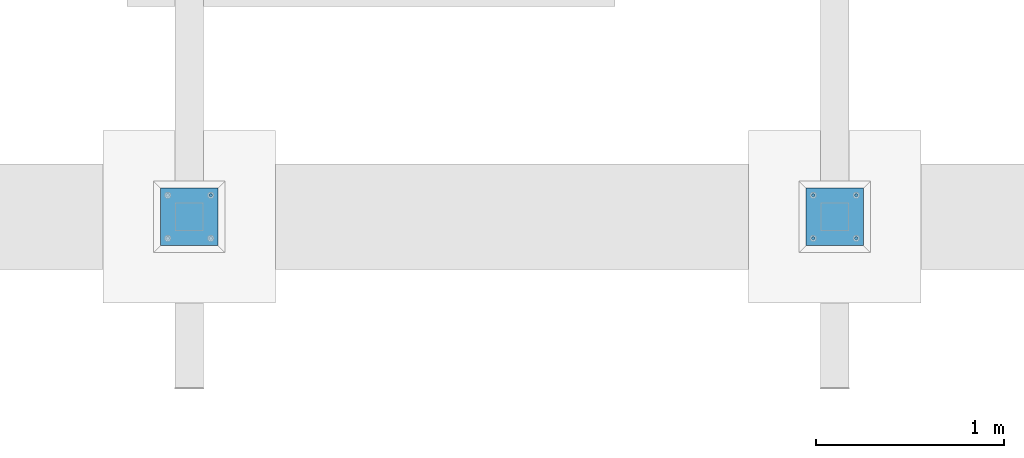
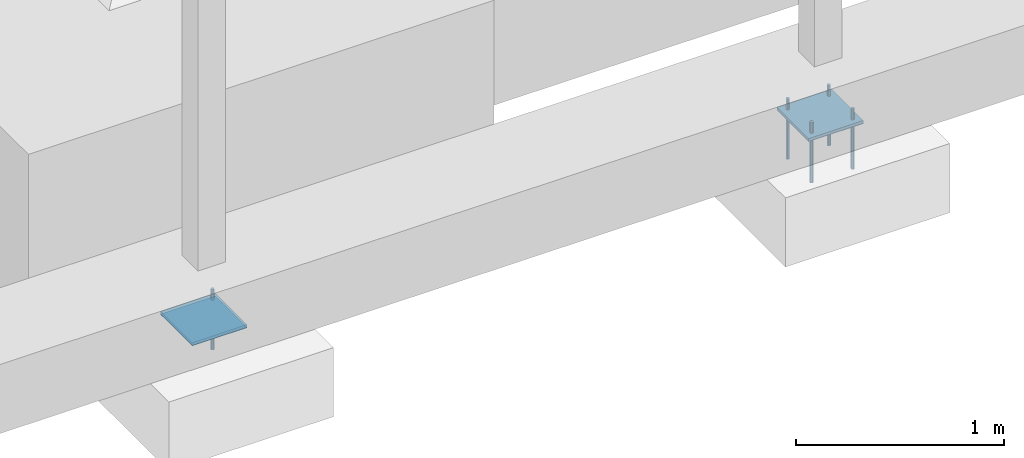
# One storey, part 846 of 1179: 9 beams, 4 elements without a shape of their own.
"""IFC2X3 building model written with IfcOpenShell, lengths in millimetres."""

from ifc_helpers import new_model, si_unit, frame, origin_with_axes, place, context, subcontext, project, spatial, faceted_brep, material, type_object, element, aggregate, save


model = new_model("IFC2X3")

# Units and contexts
model_context = context("Model", 3, precision=1e-05, world=origin_with_axes())
body_context = subcontext(model_context, "Body", "Model", "MODEL_VIEW")
ifc_project = project(units=[si_unit("LENGTHUNIT", "METRE", prefix="MILLI"), si_unit("AREAUNIT", "SQUARE_METRE"), si_unit("VOLUMEUNIT", "CUBIC_METRE"), si_unit("MASSUNIT", "GRAM", prefix="KILO"), si_unit("TIMEUNIT", "SECOND"), si_unit("PLANEANGLEUNIT", "RADIAN"), si_unit("SOLIDANGLEUNIT", "STERADIAN"), si_unit("THERMODYNAMICTEMPERATUREUNIT", "DEGREE_CELSIUS"), si_unit("LUMINOUSINTENSITYUNIT", "LUMEN")], contexts=[model_context])

# Site, building, storey
site_placement = place(None, origin_with_axes())
site = spatial("IfcSite", under=ifc_project, at=site_placement, CompositionType="ELEMENT")
building_placement = place(site_placement, origin_with_axes())
building = spatial("IfcBuilding", under=site, at=building_placement, Name="Undefined", CompositionType="ELEMENT")
storey_placement = place(building_placement, origin_with_axes())
storey = spatial("IfcBuildingStorey", under=building, at=storey_placement, Name="Undefined", CompositionType="ELEMENT", Elevation=0.0)

# Assembly, beam
assembly_1_placement = place(storey_placement, origin_with_axes())
assembly_1 = element("IfcElementAssembly", 1, at=assembly_1_placement, inside=storey, Name="COLUMN", AssemblyPlace="NOTDEFINED", PredefinedType="RIGID_FRAME")
ifc_material_1 = material(Name="STEEL/A572-GR.50")
beam_type_1 = type_object("IfcBeamType", PredefinedType="NOTDEFINED")
beam_1_placement = place(assembly_1_placement, frame((26797.0, 2082.80000305176, -765.175), z_axis=(-1.0, 0.0, 0.0), x_axis=(0.0, 1.0, 0.0)))
beam_1 = element("IfcBeam", 2, at=beam_1_placement, type_object=beam_type_1, material=ifc_material_1, context=body_context, shape_type="Brep", body=[
    faceted_brep([(0.0, 9.52500000000146, -152.4), (0.0, 9.52500000000146, 152.4), (304.799993896484, 9.52499999999998, 152.400000000001), (304.799993896484, 9.52499999999998, -152.400000000001), (0.0, -9.52500000000146, 152.4), (304.799993896484, -9.52499999999998, 152.400000000001), (0.0, -9.52500000000146, -152.4), (304.799993896484, -9.52499999999998, -152.400000000001)], [[[0, 1, 2, 3]], [[1, 4, 5, 2]], [[4, 6, 7, 5]], [[6, 0, 3, 7]], [[5, 7, 3, 2]], [[6, 4, 1, 0]]]),
])
aggregate(assembly_1, [beam_1])

assembly_2_placement = place(storey_placement, origin_with_axes())
assembly_2 = element("IfcElementAssembly", 3, at=assembly_2_placement, inside=storey, Name="COLUMN", AssemblyPlace="NOTDEFINED", PredefinedType="RIGID_FRAME")
beam_2_placement = place(assembly_2_placement, frame((30226.0, 2082.80000305176, -765.175), z_axis=(-1.0, 0.0, 0.0), x_axis=(0.0, 1.0, 0.0)))
beam_2 = element("IfcBeam", 4, at=beam_2_placement, type_object=beam_type_1, material=ifc_material_1, context=body_context, shape_type="Brep", body=[
    faceted_brep([(0.0, 9.52500000000146, -152.4), (0.0, 9.52500000000146, 152.4), (304.799993896484, 9.52499999999998, 152.400000000001), (304.799993896484, 9.52499999999998, -152.400000000001), (0.0, -9.52500000000146, 152.4), (304.799993896484, -9.52499999999998, 152.400000000001), (0.0, -9.52500000000146, -152.4), (304.799993896484, -9.52499999999998, -152.400000000001)], [[[0, 1, 2, 3]], [[1, 4, 5, 2]], [[4, 6, 7, 5]], [[6, 0, 3, 7]], [[5, 7, 3, 2]], [[6, 4, 1, 0]]]),
])
aggregate(assembly_2, [beam_2])

# Assembly, beams
assembly_3_placement = place(storey_placement, origin_with_axes())
assembly_3 = element("IfcElementAssembly", 5, at=assembly_3_placement, inside=storey, Name="TEMPLATE", AssemblyPlace="NOTDEFINED", PredefinedType="RIGID_FRAME")
ifc_material_2 = material(Name="STEEL/F1554-GR.36")
beam_type_2 = type_object("IfcBeamType", PredefinedType="NOTDEFINED")
beam_3_placement = place(assembly_3_placement, frame((30111.7, 2120.9, -812.8), z_axis=(0.0, -1.0, 0.0), x_axis=(0.0, 0.0, -1.0)))
beam_3 = element("IfcBeam", 6, at=beam_3_placement, type_object=beam_type_2, material=ifc_material_2, Name="ANCHOR_BOLT", context=body_context, shape_type="Brep", body=[
    faceted_brep([(0.0, -6.73519209080177, -6.73519209080223), (2.95075507493764e-12, -3.62376795237651e-13, -9.52499961853027), (234.949, 0.0, -9.52500000000009), (234.949, -6.73519209080405, -6.73519209080177), (0.0, 6.73519209080177, -6.73519209080223), (234.949, 6.73519209080405, -6.73519209080177), (0.0, 9.52499999999964, 0.0), (234.949, 9.52500000000146, 0.0), (0.0, 6.73519209080177, 6.73519209080223), (234.949, 6.73519209080405, 6.73519209080177), (-9.87109982941227e-13, -3.62376795237651e-13, 9.52499961853027), (234.949, 0.0, 9.52500000000009), (0.0, -6.73519209080177, 6.73519209080223), (234.949, -6.73519209080405, 6.73519209080177), (0.0, -9.52499999999964, 0.0), (234.949, -9.52500000000146, 0.0), (0.0, 6.36396103067818, 6.36396103067909), (0.0, 0.0, 9.0), (0.0, -6.36396103067818, 6.36396103067909), (0.0, -9.0, 0.0), (0.0, -6.36396103067818, -6.36396103067909), (0.0, 0.0, -9.0), (0.0, 6.36396103067818, -6.36396103067909), (0.0, 9.0, 0.0), (-120.65, -6.36396103067818, 6.36396103067909), (-120.65, 0.0, 9.0), (-120.65, 6.36396103067818, 6.36396103067909), (-120.65, 9.0, 0.0), (-120.65, 6.36396103067818, -6.36396103067909), (-120.65, 0.0, -9.0), (-120.65, -6.36396103067818, -6.36396103067909), (-120.65, -9.0, 0.0)], [[[0, 1, 2, 3]], [[1, 4, 5, 2]], [[4, 6, 7, 5]], [[6, 8, 9, 7]], [[8, 10, 11, 9]], [[10, 12, 13, 11]], [[12, 14, 15, 13]], [[2, 5, 7, 9, 11, 13, 15, 3]], [[14, 0, 3, 15]], [[12, 10, 8, 6, 4, 1, 0, 14], [16, 17, 18, 19, 20, 21, 22, 23]], [[24, 25, 26, 27, 28, 29, 30, 31]], [[26, 25, 17, 16]], [[27, 26, 16, 23]], [[28, 27, 23, 22]], [[29, 28, 22, 21]], [[30, 29, 21, 20]], [[31, 30, 20, 19]], [[24, 31, 19, 18]], [[25, 24, 18, 17]]]),
])
beam_4_placement = place(assembly_3_placement, frame((30340.3, 2120.9, -812.8), z_axis=(0.0, 1.0, 0.0), x_axis=(0.0, 0.0, -1.0)))
beam_4 = element("IfcBeam", 7, at=beam_4_placement, type_object=beam_type_2, material=ifc_material_2, Name="ANCHOR_BOLT", context=body_context, shape_type="Brep", body=[
    faceted_brep([(0.0, -6.73519209080177, -6.73519209080223), (2.95075507493764e-12, -3.62376795237651e-13, -9.52499961853027), (234.949, 0.0, -9.52500000000009), (234.949, -6.73519209080405, -6.73519209080177), (0.0, 6.73519209080177, -6.73519209080223), (234.949, 6.73519209080405, -6.73519209080177), (0.0, 9.52499999999964, 0.0), (234.949, 9.52500000000146, 0.0), (0.0, 6.73519209080177, 6.73519209080223), (234.949, 6.73519209080405, 6.73519209080177), (-9.87109982941227e-13, -3.62376795237651e-13, 9.52499961853027), (234.949, 0.0, 9.52500000000009), (0.0, -6.73519209080177, 6.73519209080223), (234.949, -6.73519209080405, 6.73519209080177), (0.0, -9.52499999999964, 0.0), (234.949, -9.52500000000146, 0.0), (0.0, 6.36396103067818, 6.36396103067909), (0.0, 0.0, 9.0), (0.0, -6.36396103067818, 6.36396103067909), (0.0, -9.0, 0.0), (0.0, -6.36396103067818, -6.36396103067909), (0.0, 0.0, -9.0), (0.0, 6.36396103067818, -6.36396103067909), (0.0, 9.0, 0.0), (-120.65, -6.36396103067818, 6.36396103067909), (-120.65, 0.0, 9.0), (-120.65, 6.36396103067818, 6.36396103067909), (-120.65, 9.0, 0.0), (-120.65, 6.36396103067818, -6.36396103067909), (-120.65, 0.0, -9.0), (-120.65, -6.36396103067818, -6.36396103067909), (-120.65, -9.0, 0.0)], [[[0, 1, 2, 3]], [[1, 4, 5, 2]], [[4, 6, 7, 5]], [[6, 8, 9, 7]], [[8, 10, 11, 9]], [[10, 12, 13, 11]], [[12, 14, 15, 13]], [[2, 5, 7, 9, 11, 13, 15, 3]], [[14, 0, 3, 15]], [[12, 10, 8, 6, 4, 1, 0, 14], [16, 17, 18, 19, 20, 21, 22, 23]], [[24, 25, 26, 27, 28, 29, 30, 31]], [[26, 25, 17, 16]], [[27, 26, 16, 23]], [[28, 27, 23, 22]], [[29, 28, 22, 21]], [[30, 29, 21, 20]], [[31, 30, 20, 19]], [[24, 31, 19, 18]], [[25, 24, 18, 17]]]),
])
beam_5_placement = place(assembly_3_placement, frame((30111.7, 2349.5, -812.8), z_axis=(0.0, -1.0, 0.0), x_axis=(0.0, 0.0, -1.0)))
beam_5 = element("IfcBeam", 8, at=beam_5_placement, type_object=beam_type_2, material=ifc_material_2, Name="ANCHOR_BOLT", context=body_context, shape_type="Brep", body=[
    faceted_brep([(0.0, -6.73519209080177, -6.73519209080223), (2.95075507493764e-12, -3.62376795237651e-13, -9.52499961853027), (234.949, 0.0, -9.52500000000009), (234.949, -6.73519209080405, -6.73519209080177), (0.0, 6.73519209080177, -6.73519209080223), (234.949, 6.73519209080405, -6.73519209080177), (0.0, 9.52499999999964, 0.0), (234.949, 9.52500000000146, 0.0), (0.0, 6.73519209080177, 6.73519209080223), (234.949, 6.73519209080405, 6.73519209080177), (-9.87109982941227e-13, -3.62376795237651e-13, 9.52499961853027), (234.949, 0.0, 9.52500000000009), (0.0, -6.73519209080177, 6.73519209080223), (234.949, -6.73519209080405, 6.73519209080177), (0.0, -9.52499999999964, 0.0), (234.949, -9.52500000000146, 0.0), (0.0, 6.36396103067818, 6.36396103067909), (0.0, 0.0, 9.0), (0.0, -6.36396103067818, 6.36396103067909), (0.0, -9.0, 0.0), (0.0, -6.36396103067818, -6.36396103067909), (0.0, 0.0, -9.0), (0.0, 6.36396103067818, -6.36396103067909), (0.0, 9.0, 0.0), (-120.65, -6.36396103067818, 6.36396103067909), (-120.65, 0.0, 9.0), (-120.65, 6.36396103067818, 6.36396103067909), (-120.65, 9.0, 0.0), (-120.65, 6.36396103067818, -6.36396103067909), (-120.65, 0.0, -9.0), (-120.65, -6.36396103067818, -6.36396103067909), (-120.65, -9.0, 0.0)], [[[0, 1, 2, 3]], [[1, 4, 5, 2]], [[4, 6, 7, 5]], [[6, 8, 9, 7]], [[8, 10, 11, 9]], [[10, 12, 13, 11]], [[12, 14, 15, 13]], [[2, 5, 7, 9, 11, 13, 15, 3]], [[14, 0, 3, 15]], [[12, 10, 8, 6, 4, 1, 0, 14], [16, 17, 18, 19, 20, 21, 22, 23]], [[24, 25, 26, 27, 28, 29, 30, 31]], [[26, 25, 17, 16]], [[27, 26, 16, 23]], [[28, 27, 23, 22]], [[29, 28, 22, 21]], [[30, 29, 21, 20]], [[31, 30, 20, 19]], [[24, 31, 19, 18]], [[25, 24, 18, 17]]]),
])
beam_6_placement = place(assembly_3_placement, frame((30340.3, 2349.5, -812.8), z_axis=(0.0, 1.0, 0.0), x_axis=(0.0, 0.0, -1.0)))
beam_6 = element("IfcBeam", 9, at=beam_6_placement, type_object=beam_type_2, material=ifc_material_2, Name="ANCHOR_BOLT", context=body_context, shape_type="Brep", body=[
    faceted_brep([(0.0, -6.73519209080177, -6.73519209080223), (2.95075507493764e-12, -3.62376795237651e-13, -9.52499961853027), (234.949, 0.0, -9.52500000000009), (234.949, -6.73519209080405, -6.73519209080177), (0.0, 6.73519209080177, -6.73519209080223), (234.949, 6.73519209080405, -6.73519209080177), (0.0, 9.52499999999964, 0.0), (234.949, 9.52500000000146, 0.0), (0.0, 6.73519209080177, 6.73519209080223), (234.949, 6.73519209080405, 6.73519209080177), (-9.87109982941227e-13, -3.62376795237651e-13, 9.52499961853027), (234.949, 0.0, 9.52500000000009), (0.0, -6.73519209080177, 6.73519209080223), (234.949, -6.73519209080405, 6.73519209080177), (0.0, -9.52499999999964, 0.0), (234.949, -9.52500000000146, 0.0), (0.0, 6.36396103067818, 6.36396103067909), (0.0, 0.0, 9.0), (0.0, -6.36396103067818, 6.36396103067909), (0.0, -9.0, 0.0), (0.0, -6.36396103067818, -6.36396103067909), (0.0, 0.0, -9.0), (0.0, 6.36396103067818, -6.36396103067909), (0.0, 9.0, 0.0), (-120.65, -6.36396103067818, 6.36396103067909), (-120.65, 0.0, 9.0), (-120.65, 6.36396103067818, 6.36396103067909), (-120.65, 9.0, 0.0), (-120.65, 6.36396103067818, -6.36396103067909), (-120.65, 0.0, -9.0), (-120.65, -6.36396103067818, -6.36396103067909), (-120.65, -9.0, 0.0)], [[[0, 1, 2, 3]], [[1, 4, 5, 2]], [[4, 6, 7, 5]], [[6, 8, 9, 7]], [[8, 10, 11, 9]], [[10, 12, 13, 11]], [[12, 14, 15, 13]], [[2, 5, 7, 9, 11, 13, 15, 3]], [[14, 0, 3, 15]], [[12, 10, 8, 6, 4, 1, 0, 14], [16, 17, 18, 19, 20, 21, 22, 23]], [[24, 25, 26, 27, 28, 29, 30, 31]], [[26, 25, 17, 16]], [[27, 26, 16, 23]], [[28, 27, 23, 22]], [[29, 28, 22, 21]], [[30, 29, 21, 20]], [[31, 30, 20, 19]], [[24, 31, 19, 18]], [[25, 24, 18, 17]]]),
])

# Assembly, beam
assembly_4_placement = place(storey_placement, origin_with_axes())
assembly_4 = element("IfcElementAssembly", 10, at=assembly_4_placement, inside=storey, Name="TEMPLATE", AssemblyPlace="NOTDEFINED", PredefinedType="RIGID_FRAME")
beam_7_placement = place(assembly_4_placement, frame((26911.3, 2349.5, -812.8), z_axis=(0.0, 1.0, 0.0), x_axis=(0.0, 0.0, -1.0)))
beam_7 = element("IfcBeam", 11, at=beam_7_placement, type_object=beam_type_2, material=ifc_material_2, Name="ANCHOR_BOLT", context=body_context, shape_type="Brep", body=[
    faceted_brep([(0.0, -6.73519209080177, -6.73519209080223), (2.95075507493764e-12, -3.62376795237651e-13, -9.52499961853027), (234.949, 0.0, -9.52500000000009), (234.949, -6.73519209080405, -6.73519209080177), (0.0, 6.73519209080177, -6.73519209080223), (234.949, 6.73519209080405, -6.73519209080177), (0.0, 9.52499999999964, 0.0), (234.949, 9.52500000000146, 0.0), (0.0, 6.73519209080177, 6.73519209080223), (234.949, 6.73519209080405, 6.73519209080177), (-9.87109982941227e-13, -3.62376795237651e-13, 9.52499961853027), (234.949, 0.0, 9.52500000000009), (0.0, -6.73519209080177, 6.73519209080223), (234.949, -6.73519209080405, 6.73519209080177), (0.0, -9.52499999999964, 0.0), (234.949, -9.52500000000146, 0.0), (0.0, 6.36396103067818, 6.36396103067909), (0.0, 0.0, 9.0), (0.0, -6.36396103067818, 6.36396103067909), (0.0, -9.0, 0.0), (0.0, -6.36396103067818, -6.36396103067909), (0.0, 0.0, -9.0), (0.0, 6.36396103067818, -6.36396103067909), (0.0, 9.0, 0.0), (-120.65, -6.36396103067818, 6.36396103067909), (-120.65, 0.0, 9.0), (-120.65, 6.36396103067818, 6.36396103067909), (-120.65, 9.0, 0.0), (-120.65, 6.36396103067818, -6.36396103067909), (-120.65, 0.0, -9.0), (-120.65, -6.36396103067818, -6.36396103067909), (-120.65, -9.0, 0.0)], [[[0, 1, 2, 3]], [[1, 4, 5, 2]], [[4, 6, 7, 5]], [[6, 8, 9, 7]], [[8, 10, 11, 9]], [[10, 12, 13, 11]], [[12, 14, 15, 13]], [[2, 5, 7, 9, 11, 13, 15, 3]], [[14, 0, 3, 15]], [[12, 10, 8, 6, 4, 1, 0, 14], [16, 17, 18, 19, 20, 21, 22, 23]], [[24, 25, 26, 27, 28, 29, 30, 31]], [[26, 25, 17, 16]], [[27, 26, 16, 23]], [[28, 27, 23, 22]], [[29, 28, 22, 21]], [[30, 29, 21, 20]], [[31, 30, 20, 19]], [[24, 31, 19, 18]], [[25, 24, 18, 17]]]),
])

# Beam
ifc_material_3 = material(Name="STEEL/A36")
beam_type_3 = type_object("IfcBeamType", PredefinedType="NOTDEFINED")
beam_8_placement = place(assembly_3_placement, frame((30226.0, 2082.80000305176, -773.1125), z_axis=(-1.0, 0.0, 0.0), x_axis=(0.0, 1.0, 0.0)))
beam_8 = element("IfcBeam", 12, at=beam_8_placement, type_object=beam_type_3, material=ifc_material_3, Name="TEMPLATE", context=body_context, shape_type="Brep", body=[
    faceted_brep([(0.0, 1.58750000000146, -152.4), (0.0, 1.58750000000146, 152.4), (304.799999999996, 1.58749999999998, 152.400000000001), (304.799999999996, 1.58749999999998, -152.400000000001), (0.0, -1.58750000000146, 152.4), (304.799999999996, -1.58749999999998, 152.400000000001), (0.0, -1.58750000000146, -152.4), (304.799999999996, -1.58749999999998, -152.400000000001)], [[[0, 1, 2, 3]], [[1, 4, 5, 2]], [[4, 6, 7, 5]], [[6, 0, 3, 7]], [[5, 7, 3, 2]], [[6, 4, 1, 0]]]),
])

aggregate(assembly_3, [beam_3, beam_4, beam_5, beam_6, beam_8])

beam_9_placement = place(assembly_4_placement, frame((26797.0, 2082.80000305176, -773.1125), z_axis=(-1.0, 0.0, 0.0), x_axis=(0.0, 1.0, 0.0)))
beam_9 = element("IfcBeam", 13, at=beam_9_placement, type_object=beam_type_3, material=ifc_material_3, Name="TEMPLATE", context=body_context, shape_type="Brep", body=[
    faceted_brep([(0.0, 1.58750000000146, -152.4), (0.0, 1.58750000000146, 152.4), (304.799999999996, 1.58749999999998, 152.400000000001), (304.799999999996, 1.58749999999998, -152.400000000001), (0.0, -1.58750000000146, 152.4), (304.799999999996, -1.58749999999998, 152.400000000001), (0.0, -1.58750000000146, -152.4), (304.799999999996, -1.58749999999998, -152.400000000001)], [[[0, 1, 2, 3]], [[1, 4, 5, 2]], [[4, 6, 7, 5]], [[6, 0, 3, 7]], [[5, 7, 3, 2]], [[6, 4, 1, 0]]]),
])

aggregate(assembly_4, [beam_7, beam_9])

save(model, "model.ifc")
